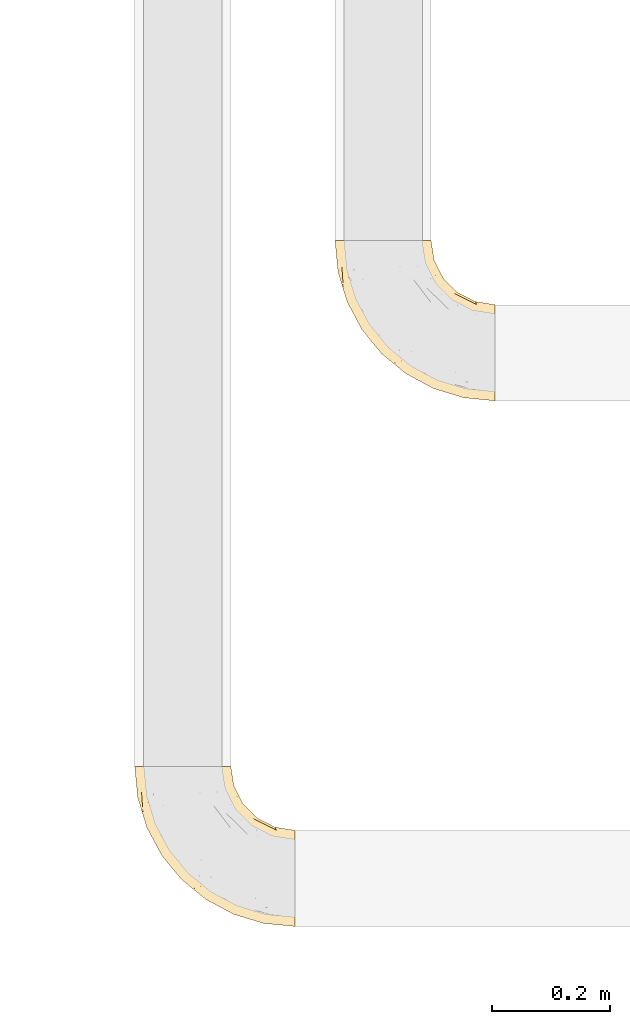
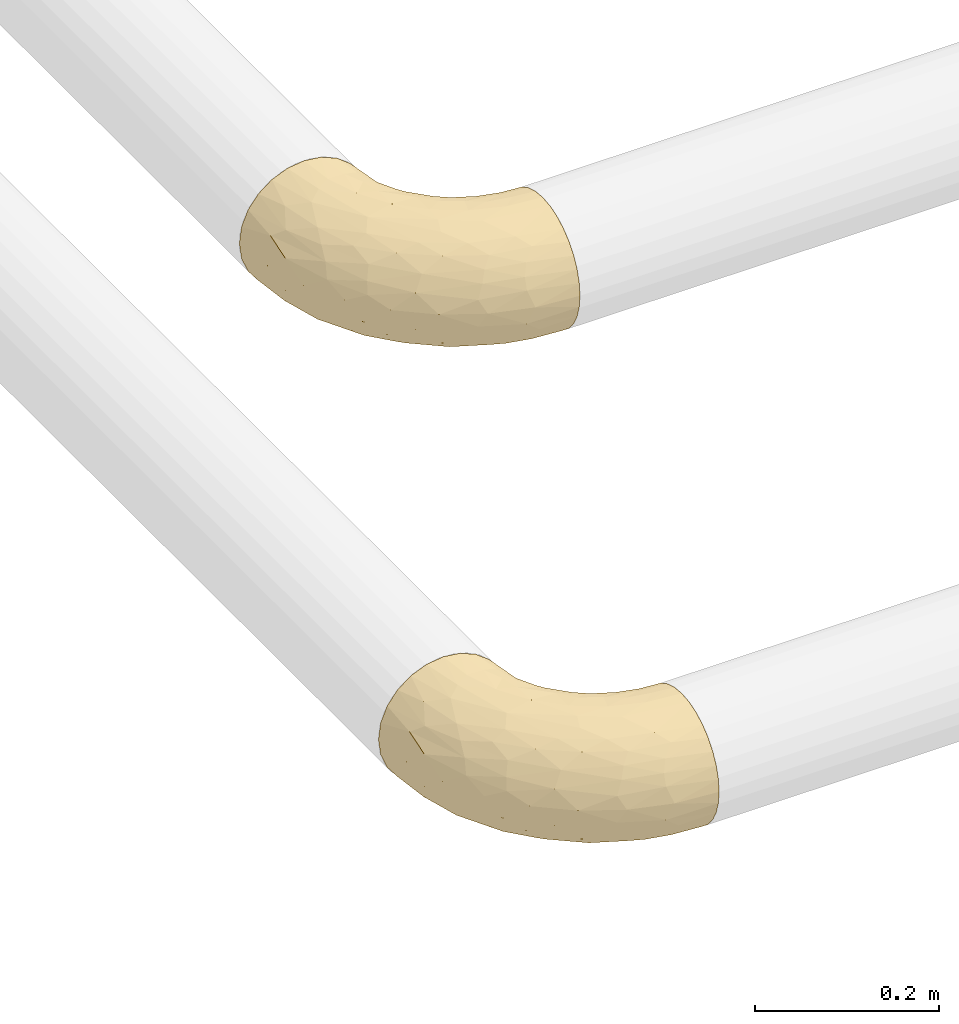
# One storey, part 97 of 827: 2 coverings.
"""IFC2X3 building model written with IfcOpenShell, lengths in millimetres."""

from ifc_helpers import new_model, entity, si_unit, converted_unit, derived_unit, direction, frame, origin, place, context, subcontext, project, spatial, faceted_brep, element, save


model = new_model("IFC2X3")

# Units and contexts
model_context = context("Model", 3, precision=0.01, world=origin(), true_north=direction((6.12303176911189e-17, 1.0)))
body_context = subcontext(model_context, "Body", "Model", "MODEL_VIEW")
ifc_project = project(units=[si_unit("LENGTHUNIT", "METRE", prefix="MILLI"), si_unit("AREAUNIT", "SQUARE_METRE"), si_unit("VOLUMEUNIT", "CUBIC_METRE"), converted_unit("PLANEANGLEUNIT", "DEGREE", entity("IfcRatioMeasure", 0.0174532925199433), si_unit("PLANEANGLEUNIT", "RADIAN"), dimensions=[0, 0, 0, 0, 0, 0, 0]), si_unit("MASSUNIT", "GRAM", prefix="KILO"), derived_unit("MASSDENSITYUNIT", [(si_unit("MASSUNIT", "GRAM", prefix="KILO"), 1), (si_unit("LENGTHUNIT", "METRE"), -3)]), derived_unit("MOMENTOFINERTIAUNIT", [(si_unit("LENGTHUNIT", "METRE"), 4)]), si_unit("TIMEUNIT", "SECOND"), si_unit("FREQUENCYUNIT", "HERTZ"), si_unit("THERMODYNAMICTEMPERATUREUNIT", "DEGREE_CELSIUS"), derived_unit("THERMALTRANSMITTANCEUNIT", [(si_unit("MASSUNIT", "GRAM", prefix="KILO"), 1), (si_unit("THERMODYNAMICTEMPERATUREUNIT", "KELVIN"), -1), (si_unit("TIMEUNIT", "SECOND"), -3)]), derived_unit("VOLUMETRICFLOWRATEUNIT", [(si_unit("LENGTHUNIT", "METRE"), 3), (si_unit("TIMEUNIT", "SECOND"), -1)]), derived_unit("MASSFLOWRATEUNIT", [(si_unit("MASSUNIT", "GRAM", prefix="KILO"), 1), (si_unit("TIMEUNIT", "SECOND"), -1)]), derived_unit("ROTATIONALFREQUENCYUNIT", [(si_unit("TIMEUNIT", "SECOND"), -1)]), si_unit("ELECTRICCURRENTUNIT", "AMPERE"), si_unit("ELECTRICVOLTAGEUNIT", "VOLT"), si_unit("POWERUNIT", "WATT"), si_unit("FORCEUNIT", "NEWTON", prefix="KILO"), si_unit("ILLUMINANCEUNIT", "LUX"), si_unit("LUMINOUSFLUXUNIT", "LUMEN"), si_unit("LUMINOUSINTENSITYUNIT", "CANDELA"), derived_unit("USERDEFINED", [(si_unit("MASSUNIT", "GRAM", prefix="KILO"), -1), (si_unit("LENGTHUNIT", "METRE"), -2), (si_unit("TIMEUNIT", "SECOND"), 3), (si_unit("LUMINOUSFLUXUNIT", "LUMEN"), 1)]), derived_unit("LINEARVELOCITYUNIT", [(si_unit("LENGTHUNIT", "METRE"), 1), (si_unit("TIMEUNIT", "SECOND"), -1)]), si_unit("PRESSUREUNIT", "PASCAL"), derived_unit("USERDEFINED", [(si_unit("LENGTHUNIT", "METRE"), -2), (si_unit("MASSUNIT", "GRAM", prefix="KILO"), 1), (si_unit("TIMEUNIT", "SECOND"), -2)]), derived_unit("LINEARFORCEUNIT", [(si_unit("MASSUNIT", "GRAM", prefix="KILO"), 1), (si_unit("LENGTHUNIT", "METRE"), 1), (si_unit("TIMEUNIT", "SECOND"), -2), (si_unit("LENGTHUNIT", "METRE"), -1)]), derived_unit("PLANARFORCEUNIT", [(si_unit("MASSUNIT", "GRAM", prefix="KILO"), 1), (si_unit("LENGTHUNIT", "METRE"), 1), (si_unit("TIMEUNIT", "SECOND"), -2), (si_unit("LENGTHUNIT", "METRE"), -2)])], contexts=[model_context])

# Site, building, storey
site_placement = place(None, origin())
site = spatial("IfcSite", under=ifc_project, at=site_placement, CompositionType="ELEMENT")
building_placement = place(site_placement, origin())
building = spatial("IfcBuilding", under=site, at=building_placement, CompositionType="ELEMENT")
storey_placement = place(building_placement, frame((0.0, 0.0, 28200.0)))
storey = spatial("IfcBuildingStorey", under=building, at=storey_placement, Name="08", CompositionType="ELEMENT", Elevation=28200.0)

# Coverings
covering_1_placement = place(storey_placement, frame((22091.66, 7183.11, 2716.91)))
element("IfcCovering", 1, at=covering_1_placement, inside=storey, Name=":ADSK_", ObjectType=":ADSK_", PredefinedType="INSULATION", context=body_context, shape_type="Brep", body=[
    faceted_brep([(273.1, 51.91, 158.39), (273.1, 37.82, 150.86), (273.1, 25.47, 140.72), (273.1, 15.33, 128.37), (273.1, 7.8, 114.28), (273.1, 3.16, 98.99), (273.1, 1.6, 83.1), (273.1, 3.16, 67.2), (273.1, 7.8, 51.91), (273.1, 15.33, 37.82), (273.1, 25.47, 25.47), (273.1, 37.82, 15.33), (273.1, 51.91, 7.8), (273.1, 67.2, 3.16), (273.1, 83.1, 1.6), (273.1, 99.0, 3.16), (273.1, 114.28, 7.8), (273.1, 128.37, 15.33), (273.1, 140.72, 25.47), (273.1, 150.86, 37.82), (273.1, 158.39, 51.91), (273.1, 163.03, 67.2), (273.1, 164.6, 83.1), (273.1, 163.03, 99.0), (273.1, 158.39, 114.28), (273.1, 150.86, 128.37), (273.1, 140.72, 140.72), (273.1, 128.37, 150.86), (273.1, 114.28, 158.39), (273.1, 98.99, 163.03), (273.1, 83.1, 164.6), (273.1, 67.2, 163.03), (161.82, 273.1, 62.0), (153.68, 273.1, 42.35), (140.72, 273.1, 25.47), (123.85, 273.1, 12.51), (104.19, 273.1, 4.37), (83.1, 273.1, 1.6), (62.0, 273.1, 4.37), (42.35, 273.1, 12.51), (25.47, 273.1, 25.47), (12.51, 273.1, 42.35), (4.37, 273.1, 62.0), (1.6, 273.1, 83.1), (4.37, 273.1, 104.19), (12.51, 273.1, 123.85), (25.47, 273.1, 140.72), (42.35, 273.1, 153.68), (62.0, 273.1, 161.82), (83.1, 273.1, 164.6), (104.19, 273.1, 161.82), (123.85, 273.1, 153.68), (140.72, 273.1, 140.72), (153.68, 273.1, 123.85), (161.82, 273.1, 104.19), (164.6, 273.1, 83.1), (15.45, 197.18, 104.67), (6.81, 220.13, 83.1), (22.26, 169.2, 83.1), (42.42, 165.22, 132.71), (71.44, 112.74, 128.57), (65.97, 136.63, 140.31), (113.44, 69.59, 127.0), (65.75, 106.1, 111.93), (103.59, 65.75, 107.33), (63.94, 101.73, 96.47), (218.6, 47.92, 153.13), (39.77, 151.7, 119.3), (36.91, 143.42, 101.32), (138.84, 67.74, 142.92), (183.71, 44.25, 142.61), (168.19, 64.23, 151.87), (71.48, 221.53, 162.56), (101.91, 190.66, 164.6), (87.86, 230.82, 164.6), (47.35, 122.26, 83.1), (167.63, 31.44, 117.97), (212.84, 17.25, 119.64), (173.72, 37.36, 131.15), (81.12, 81.12, 83.1), (122.26, 47.35, 83.1), (56.45, 210.98, 156.52), (46.95, 181.7, 144.21), (35.05, 232.28, 146.25), (24.32, 211.28, 130.43), (230.82, 87.86, 164.6), (195.92, 79.61, 162.51), (92.81, 152.2, 159.97), (82.34, 136.41, 151.26), (122.78, 92.77, 151.21), (13.53, 226.05, 117.68), (149.02, 89.58, 158.25), (154.38, 104.94, 163.04), (212.27, 11.64, 105.24), (160.47, 28.2, 100.78), (230.92, 33.2, 144.52), (98.82, 98.82, 141.87), (218.75, 24.35, 132.77), (169.2, 22.26, 83.1), (220.13, 6.81, 83.1), (190.66, 101.91, 164.6), (154.63, 124.55, 164.6), (124.55, 154.63, 164.6), (131.16, 242.08, 151.23), (150.42, 231.65, 137.69), (110.62, 233.63, 161.34), (211.28, 155.43, 141.27), (240.6, 146.77, 138.72), (223.71, 162.22, 127.05), (203.39, 184.19, 109.71), (239.57, 169.91, 83.1), (209.32, 185.32, 83.1), (171.53, 213.9, 120.43), (166.55, 197.8, 138.75), (191.93, 180.95, 129.2), (173.04, 136.57, 161.91), (198.01, 123.35, 161.43), (187.52, 145.64, 155.97), (125.16, 185.45, 162.57), (157.77, 157.77, 160.03), (158.24, 182.66, 151.82), (160.57, 245.12, 117.14), (242.02, 164.57, 109.48), (248.61, 133.28, 148.92), (220.59, 136.47, 151.93), (137.18, 206.49, 154.85), (165.92, 248.1, 98.92), (175.12, 222.02, 100.98), (185.32, 209.32, 83.1), (169.91, 239.57, 83.1), (184.45, 167.88, 145.5), (238.32, 118.7, 158.16), (217.41, 108.44, 162.97), (245.77, 102.71, 162.71), (190.73, 200.15, 98.76), (121.56, 211.84, 160.15), (249.77, 155.81, 124.12), (171.52, 162.83, 154.06), (137.18, 206.49, 11.34), (150.42, 231.65, 28.5), (166.55, 197.8, 27.44), (158.24, 182.66, 14.37), (165.92, 248.1, 67.27), (175.12, 222.02, 65.22), (223.71, 162.22, 39.14), (211.28, 155.43, 24.93), (191.92, 180.95, 36.99), (245.77, 102.71, 3.48), (203.4, 184.19, 56.48), (131.16, 242.08, 14.96), (110.62, 233.63, 4.85), (249.77, 155.81, 42.07), (240.6, 146.78, 27.47), (171.53, 213.9, 45.76), (190.73, 200.15, 67.43), (217.41, 108.44, 3.22), (238.31, 118.7, 8.03), (87.86, 230.82, 1.6), (160.57, 245.12, 49.05), (248.61, 133.28, 17.27), (242.02, 164.57, 56.71), (111.86, 206.34, 3.08), (125.16, 185.45, 3.62), (190.66, 101.91, 1.6), (154.63, 124.55, 1.6), (198.01, 123.35, 4.76), (124.55, 154.63, 1.6), (101.91, 190.66, 1.6), (184.45, 167.88, 20.69), (157.77, 157.77, 6.16), (220.59, 136.47, 14.26), (187.52, 145.64, 10.22), (173.04, 136.57, 4.28), (230.82, 87.86, 1.6), (171.95, 162.96, 12.35), (24.32, 211.28, 35.76), (183.71, 44.25, 23.58), (173.75, 37.35, 35.03), (133.19, 59.81, 34.03), (229.24, 14.04, 46.35), (79.61, 195.92, 3.68), (104.94, 154.38, 3.15), (89.58, 149.02, 7.94), (98.82, 98.82, 24.32), (84.08, 94.45, 41.48), (152.2, 92.81, 6.22), (198.75, 82.48, 2.91), (62.55, 108.3, 57.48), (58.85, 198.33, 10.43), (40.65, 169.99, 33.0), (46.95, 181.7, 21.98), (63.87, 135.99, 28.1), (22.06, 192.96, 47.91), (230.92, 33.21, 21.67), (103.59, 65.75, 58.86), (207.65, 49.37, 13.93), (39.77, 151.7, 46.9), (34.68, 148.6, 62.93), (35.05, 232.28, 19.94), (15.45, 197.18, 61.52), (150.41, 72.78, 15.08), (210.73, 63.87, 6.68), (160.46, 28.2, 65.41), (79.42, 136.17, 16.65), (115.1, 107.34, 11.53), (212.26, 11.64, 60.95), (218.75, 24.35, 33.42), (167.63, 31.44, 48.22)], [[[0, 1, 2, 3, 4, 5, 6, 7, 8, 9, 10, 11, 12, 13, 14, 15, 16, 17, 18, 19, 20, 21, 22, 23, 24, 25, 26, 27, 28, 29, 30, 31]], [[32, 33, 34, 35, 36, 37, 38, 39, 40, 41, 42, 43, 44, 45, 46, 47, 48, 49, 50, 51, 52, 53, 54, 55]], [[56, 57, 58]], [[57, 44, 43]], [[59, 60, 61]], [[62, 63, 64]], [[63, 65, 64]], [[1, 0, 66]], [[67, 68, 63]], [[69, 70, 71]], [[72, 73, 74]], [[75, 68, 58]], [[76, 77, 78]], [[64, 79, 80]], [[81, 48, 47]], [[82, 83, 84]], [[31, 85, 86]], [[71, 70, 66]], [[47, 83, 81]], [[87, 88, 89]], [[69, 62, 78]], [[49, 48, 72]], [[90, 44, 56]], [[48, 81, 72]], [[87, 91, 92]], [[93, 76, 94]], [[70, 95, 66]], [[88, 96, 89]], [[45, 84, 46]], [[2, 95, 97]], [[4, 93, 5]], [[98, 99, 93]], [[59, 84, 67]], [[3, 97, 77]], [[71, 86, 91]], [[4, 3, 77]], [[90, 84, 45]], [[99, 6, 5]], [[83, 47, 46]], [[95, 2, 1]], [[94, 80, 98]], [[100, 101, 92]], [[66, 31, 86]], [[60, 63, 62]], [[85, 31, 30]], [[102, 87, 92]], [[93, 77, 76]], [[91, 86, 92]], [[44, 57, 56]], [[86, 85, 100]], [[78, 97, 70]], [[87, 102, 73]], [[2, 97, 3]], [[67, 84, 90]], [[31, 66, 0]], [[93, 94, 98]], [[88, 81, 82]], [[99, 5, 93]], [[87, 73, 72]], [[66, 95, 1]], [[97, 95, 70]], [[86, 71, 66]], [[69, 89, 96]], [[89, 71, 91]], [[69, 96, 62]], [[60, 62, 96]], [[76, 62, 64]], [[71, 89, 69]], [[87, 89, 91]], [[81, 88, 87]], [[61, 88, 82]], [[61, 60, 96]], [[60, 67, 63]], [[68, 67, 56]], [[79, 65, 75]], [[58, 68, 56]], [[65, 68, 75]], [[64, 65, 79]], [[68, 65, 63]], [[76, 64, 94]], [[80, 94, 64]], [[100, 92, 86]], [[92, 101, 102]], [[88, 61, 96]], [[59, 61, 82]], [[84, 59, 82]], [[60, 59, 67]], [[87, 72, 81]], [[49, 72, 74]], [[84, 83, 46]], [[81, 83, 82]], [[69, 78, 70]], [[62, 76, 78]], [[4, 77, 93]], [[78, 77, 97]], [[44, 90, 45]], [[67, 90, 56]], [[103, 104, 52]], [[50, 49, 74]], [[50, 74, 105]], [[106, 107, 108]], [[109, 110, 111]], [[112, 113, 114]], [[104, 113, 112]], [[73, 105, 74]], [[115, 116, 117]], [[118, 119, 120]], [[104, 53, 52]], [[51, 103, 52]], [[53, 121, 54]], [[24, 23, 122]], [[123, 107, 124]], [[122, 109, 108]], [[125, 120, 113]], [[55, 54, 126]], [[102, 118, 73]], [[127, 126, 121]], [[128, 129, 127]], [[105, 51, 50]], [[102, 101, 119]], [[120, 130, 113]], [[26, 123, 27]], [[27, 131, 28]], [[132, 85, 133]], [[85, 29, 133]], [[134, 111, 128]], [[28, 133, 29]], [[30, 29, 85]], [[116, 131, 124]], [[135, 73, 118]], [[27, 123, 131]], [[110, 23, 22]], [[136, 122, 108]], [[24, 136, 25]], [[114, 108, 109]], [[119, 115, 117]], [[136, 107, 25]], [[128, 127, 134]], [[122, 110, 109]], [[104, 112, 121]], [[107, 106, 124]], [[107, 26, 25]], [[23, 110, 122]], [[101, 100, 116]], [[131, 132, 133]], [[105, 135, 103]], [[116, 124, 117]], [[122, 136, 24]], [[107, 136, 108]], [[28, 131, 133]], [[131, 116, 132]], [[126, 127, 129]], [[134, 112, 109]], [[107, 123, 26]], [[131, 123, 124]], [[104, 121, 53]], [[127, 121, 112]], [[105, 103, 51]], [[104, 103, 125]], [[116, 100, 132]], [[85, 132, 100]], [[106, 117, 124]], [[137, 130, 120]], [[114, 106, 108]], [[106, 130, 117]], [[119, 118, 102]], [[135, 118, 125]], [[125, 113, 104]], [[114, 113, 130]], [[114, 130, 106]], [[112, 114, 109]], [[118, 120, 125]], [[117, 137, 119]], [[55, 126, 129]], [[121, 126, 54]], [[112, 134, 127]], [[111, 134, 109]], [[119, 101, 115]], [[101, 116, 115]], [[103, 135, 125]], [[73, 135, 105]], [[130, 137, 117]], [[120, 119, 137]], [[138, 139, 140]], [[140, 141, 138]], [[55, 129, 142]], [[143, 142, 129]], [[144, 145, 146]], [[147, 16, 15]], [[110, 148, 111]], [[128, 143, 129]], [[149, 150, 35]], [[151, 152, 144]], [[153, 143, 154]], [[147, 155, 156]], [[35, 150, 36]], [[37, 36, 157]], [[35, 34, 149]], [[139, 33, 158]], [[159, 152, 18]], [[150, 157, 36]], [[140, 139, 153]], [[139, 34, 33]], [[110, 21, 160]], [[150, 161, 157]], [[20, 19, 151]], [[161, 138, 162]], [[110, 22, 21]], [[163, 164, 165]], [[166, 167, 162]], [[151, 160, 20]], [[140, 146, 168]], [[111, 148, 154]], [[164, 166, 169]], [[18, 152, 19]], [[170, 156, 165]], [[17, 159, 18]], [[158, 33, 32]], [[171, 165, 172]], [[155, 165, 156]], [[148, 110, 160]], [[170, 159, 156]], [[160, 144, 148]], [[15, 14, 173]], [[170, 171, 145]], [[149, 139, 138]], [[15, 173, 147]], [[144, 152, 145]], [[156, 17, 16]], [[165, 171, 170]], [[20, 160, 21]], [[171, 172, 169]], [[169, 166, 162]], [[152, 151, 19]], [[160, 151, 144]], [[155, 173, 163]], [[156, 16, 147]], [[154, 143, 128]], [[143, 153, 158]], [[156, 159, 17]], [[152, 159, 170]], [[158, 32, 142]], [[139, 158, 153]], [[139, 149, 34]], [[150, 149, 138]], [[173, 155, 147]], [[163, 165, 155]], [[174, 169, 141]], [[145, 171, 168]], [[170, 145, 152]], [[146, 145, 168]], [[161, 162, 167]], [[162, 138, 141]], [[146, 153, 148]], [[140, 168, 141]], [[153, 146, 140]], [[144, 146, 148]], [[174, 141, 168]], [[162, 141, 169]], [[158, 142, 143]], [[55, 142, 32]], [[111, 154, 128]], [[153, 154, 148]], [[165, 164, 172]], [[164, 169, 172]], [[157, 161, 167]], [[138, 161, 150]], [[168, 171, 174]], [[169, 174, 171]], [[41, 40, 175]], [[176, 177, 178]], [[9, 8, 179]], [[180, 181, 182]], [[157, 180, 37]], [[183, 178, 184]], [[164, 185, 181]], [[13, 186, 173]], [[187, 79, 75]], [[167, 166, 181]], [[186, 163, 173]], [[182, 188, 180]], [[57, 43, 42]], [[189, 190, 191]], [[164, 186, 185]], [[192, 41, 175]], [[193, 11, 10]], [[178, 194, 184]], [[12, 11, 195]], [[196, 187, 197]], [[40, 198, 175]], [[198, 40, 39]], [[58, 199, 197]], [[200, 185, 201]], [[163, 186, 164]], [[201, 185, 186]], [[202, 80, 194]], [[190, 203, 191]], [[201, 186, 13]], [[204, 185, 200]], [[201, 13, 12]], [[41, 199, 42]], [[195, 200, 201]], [[98, 205, 99]], [[57, 42, 199]], [[13, 173, 14]], [[58, 57, 199]], [[193, 206, 176]], [[80, 79, 194]], [[207, 205, 202]], [[196, 184, 187]], [[202, 205, 98]], [[205, 179, 8]], [[9, 206, 10]], [[207, 206, 179]], [[182, 203, 188]], [[6, 99, 7]], [[188, 38, 180]], [[203, 182, 204]], [[7, 205, 8]], [[37, 180, 38]], [[167, 180, 157]], [[7, 99, 205]], [[182, 181, 185]], [[11, 193, 195]], [[196, 191, 184]], [[175, 189, 192]], [[198, 188, 190]], [[38, 188, 39]], [[206, 193, 10]], [[195, 193, 176]], [[195, 176, 200]], [[12, 195, 201]], [[178, 200, 176]], [[185, 204, 182]], [[200, 183, 204]], [[203, 204, 183]], [[191, 203, 183]], [[188, 203, 190]], [[184, 191, 183]], [[190, 189, 175]], [[200, 178, 183]], [[184, 194, 187]], [[177, 176, 206]], [[194, 178, 207]], [[79, 187, 194]], [[197, 199, 192]], [[187, 75, 197]], [[58, 197, 75]], [[191, 196, 189]], [[192, 189, 196]], [[80, 202, 98]], [[194, 207, 202]], [[167, 181, 180]], [[181, 166, 164]], [[188, 198, 39]], [[175, 198, 190]], [[207, 179, 205]], [[9, 179, 206]], [[197, 192, 196]], [[41, 192, 199]], [[206, 207, 177]], [[207, 178, 177]]]),
])
covering_2_placement = place(storey_placement, frame((21752.01, 6291.9, 2716.9)))
element("IfcCovering", 2, at=covering_2_placement, inside=storey, Name=":ADSK_", ObjectType=":ADSK_", PredefinedType="INSULATION", context=body_context, shape_type="Brep", body=[
    faceted_brep([(273.1, 51.91, 158.39), (273.1, 37.82, 150.86), (273.1, 25.47, 140.72), (273.1, 15.33, 128.37), (273.1, 7.8, 114.28), (273.1, 3.16, 98.99), (273.1, 1.6, 83.1), (273.1, 3.16, 67.2), (273.1, 7.8, 51.91), (273.1, 15.33, 37.82), (273.1, 25.47, 25.47), (273.1, 37.82, 15.33), (273.1, 51.91, 7.8), (273.1, 67.2, 3.16), (273.1, 83.1, 1.6), (273.1, 99.0, 3.16), (273.1, 114.28, 7.8), (273.1, 128.37, 15.33), (273.1, 140.72, 25.47), (273.1, 150.86, 37.82), (273.1, 158.39, 51.91), (273.1, 163.03, 67.2), (273.1, 164.6, 83.1), (273.1, 163.03, 99.0), (273.1, 158.39, 114.28), (273.1, 150.86, 128.37), (273.1, 140.72, 140.72), (273.1, 128.37, 150.86), (273.1, 114.28, 158.39), (273.1, 98.99, 163.03), (273.1, 83.1, 164.6), (273.1, 67.2, 163.03), (161.82, 273.1, 62.0), (153.68, 273.1, 42.35), (140.72, 273.1, 25.47), (123.85, 273.1, 12.51), (104.19, 273.1, 4.37), (83.1, 273.1, 1.6), (62.0, 273.1, 4.37), (42.35, 273.1, 12.51), (25.47, 273.1, 25.47), (12.51, 273.1, 42.35), (4.37, 273.1, 62.0), (1.6, 273.1, 83.1), (4.37, 273.1, 104.19), (12.51, 273.1, 123.85), (25.47, 273.1, 140.72), (42.35, 273.1, 153.68), (62.0, 273.1, 161.82), (83.1, 273.1, 164.6), (104.19, 273.1, 161.82), (123.85, 273.1, 153.68), (140.72, 273.1, 140.72), (153.68, 273.1, 123.85), (161.82, 273.1, 104.19), (164.6, 273.1, 83.1), (15.45, 197.18, 104.67), (6.81, 220.13, 83.1), (22.26, 169.2, 83.1), (42.42, 165.22, 132.71), (71.44, 112.74, 128.57), (65.97, 136.63, 140.31), (113.44, 69.59, 127.0), (65.75, 106.1, 111.93), (103.59, 65.75, 107.33), (63.94, 101.73, 96.47), (218.6, 47.92, 153.13), (39.77, 151.7, 119.3), (36.91, 143.42, 101.32), (138.84, 67.74, 142.92), (183.71, 44.25, 142.61), (168.19, 64.23, 151.87), (71.48, 221.53, 162.56), (101.91, 190.66, 164.6), (87.86, 230.82, 164.6), (47.35, 122.26, 83.1), (167.63, 31.44, 117.97), (212.84, 17.25, 119.64), (173.72, 37.36, 131.15), (81.12, 81.12, 83.1), (122.26, 47.35, 83.1), (56.45, 210.98, 156.52), (46.95, 181.7, 144.21), (35.05, 232.28, 146.25), (24.32, 211.28, 130.43), (230.82, 87.86, 164.6), (195.92, 79.61, 162.51), (92.81, 152.2, 159.97), (82.34, 136.41, 151.26), (122.78, 92.77, 151.21), (13.53, 226.05, 117.68), (149.02, 89.58, 158.25), (154.38, 104.94, 163.04), (212.27, 11.64, 105.24), (160.47, 28.2, 100.78), (230.92, 33.2, 144.52), (98.82, 98.82, 141.87), (218.75, 24.35, 132.77), (169.2, 22.26, 83.1), (220.13, 6.81, 83.1), (190.66, 101.91, 164.6), (154.63, 124.55, 164.6), (124.55, 154.63, 164.6), (131.16, 242.08, 151.23), (150.42, 231.65, 137.69), (110.62, 233.63, 161.34), (211.28, 155.43, 141.27), (240.6, 146.77, 138.72), (223.71, 162.22, 127.05), (203.39, 184.19, 109.71), (239.57, 169.91, 83.1), (209.32, 185.32, 83.1), (171.53, 213.9, 120.43), (166.55, 197.8, 138.75), (191.93, 180.95, 129.2), (173.04, 136.57, 161.91), (198.01, 123.35, 161.43), (187.52, 145.64, 155.97), (125.16, 185.45, 162.57), (157.77, 157.77, 160.03), (158.24, 182.66, 151.82), (160.57, 245.12, 117.14), (242.02, 164.57, 109.48), (248.61, 133.28, 148.92), (220.59, 136.47, 151.93), (137.18, 206.49, 154.85), (165.92, 248.1, 98.92), (175.12, 222.02, 100.98), (185.32, 209.32, 83.1), (169.91, 239.57, 83.1), (184.45, 167.88, 145.5), (238.32, 118.7, 158.16), (217.41, 108.44, 162.97), (245.77, 102.71, 162.71), (190.73, 200.15, 98.76), (121.56, 211.84, 160.15), (249.77, 155.81, 124.12), (171.52, 162.83, 154.06), (137.18, 206.49, 11.34), (150.42, 231.65, 28.5), (166.55, 197.8, 27.44), (158.24, 182.66, 14.37), (165.92, 248.1, 67.27), (175.12, 222.02, 65.22), (223.71, 162.22, 39.14), (211.28, 155.43, 24.93), (191.92, 180.95, 36.99), (245.77, 102.71, 3.48), (203.4, 184.19, 56.48), (131.16, 242.08, 14.96), (110.62, 233.63, 4.85), (249.77, 155.81, 42.07), (240.6, 146.78, 27.47), (171.53, 213.9, 45.76), (190.73, 200.15, 67.43), (217.41, 108.44, 3.22), (238.31, 118.7, 8.03), (87.86, 230.82, 1.6), (160.57, 245.12, 49.05), (248.61, 133.28, 17.27), (242.02, 164.57, 56.71), (111.86, 206.34, 3.08), (125.16, 185.45, 3.62), (190.66, 101.91, 1.6), (154.63, 124.55, 1.6), (198.01, 123.35, 4.76), (124.55, 154.63, 1.6), (101.91, 190.66, 1.6), (184.45, 167.88, 20.69), (157.77, 157.77, 6.16), (220.59, 136.47, 14.26), (187.52, 145.64, 10.22), (173.04, 136.57, 4.28), (230.82, 87.86, 1.6), (171.95, 162.96, 12.35), (24.32, 211.28, 35.76), (183.71, 44.25, 23.58), (173.75, 37.35, 35.03), (133.19, 59.81, 34.03), (229.24, 14.04, 46.35), (79.61, 195.92, 3.68), (104.94, 154.38, 3.15), (89.58, 149.02, 7.94), (98.82, 98.82, 24.32), (84.08, 94.45, 41.48), (152.2, 92.81, 6.22), (198.75, 82.48, 2.91), (62.55, 108.3, 57.48), (58.85, 198.33, 10.43), (40.65, 169.99, 33.0), (46.95, 181.7, 21.98), (63.87, 135.99, 28.1), (22.06, 192.96, 47.91), (230.92, 33.21, 21.67), (103.59, 65.75, 58.86), (207.65, 49.37, 13.93), (39.77, 151.7, 46.89), (34.68, 148.6, 62.93), (35.05, 232.28, 19.94), (15.45, 197.18, 61.52), (150.41, 72.78, 15.08), (210.73, 63.87, 6.68), (160.46, 28.2, 65.41), (79.42, 136.17, 16.65), (115.1, 107.34, 11.53), (212.26, 11.64, 60.95), (218.75, 24.35, 33.42), (167.63, 31.44, 48.22)], [[[0, 1, 2, 3, 4, 5, 6, 7, 8, 9, 10, 11, 12, 13, 14, 15, 16, 17, 18, 19, 20, 21, 22, 23, 24, 25, 26, 27, 28, 29, 30, 31]], [[32, 33, 34, 35, 36, 37, 38, 39, 40, 41, 42, 43, 44, 45, 46, 47, 48, 49, 50, 51, 52, 53, 54, 55]], [[56, 57, 58]], [[57, 44, 43]], [[59, 60, 61]], [[62, 63, 64]], [[63, 65, 64]], [[1, 0, 66]], [[67, 68, 63]], [[69, 70, 71]], [[72, 73, 74]], [[75, 68, 58]], [[76, 77, 78]], [[64, 79, 80]], [[81, 48, 47]], [[82, 83, 84]], [[31, 85, 86]], [[71, 70, 66]], [[47, 83, 81]], [[87, 88, 89]], [[69, 62, 78]], [[49, 48, 72]], [[90, 44, 56]], [[48, 81, 72]], [[87, 91, 92]], [[93, 76, 94]], [[70, 95, 66]], [[88, 96, 89]], [[45, 84, 46]], [[2, 95, 97]], [[4, 93, 5]], [[98, 99, 93]], [[59, 84, 67]], [[3, 97, 77]], [[71, 86, 91]], [[4, 3, 77]], [[90, 84, 45]], [[99, 6, 5]], [[83, 47, 46]], [[95, 2, 1]], [[94, 80, 98]], [[100, 101, 92]], [[66, 31, 86]], [[60, 63, 62]], [[85, 31, 30]], [[102, 87, 92]], [[93, 77, 76]], [[91, 86, 92]], [[44, 57, 56]], [[86, 85, 100]], [[78, 97, 70]], [[87, 102, 73]], [[2, 97, 3]], [[67, 84, 90]], [[31, 66, 0]], [[93, 94, 98]], [[88, 81, 82]], [[99, 5, 93]], [[87, 73, 72]], [[66, 95, 1]], [[97, 95, 70]], [[86, 71, 66]], [[69, 89, 96]], [[89, 71, 91]], [[69, 96, 62]], [[60, 62, 96]], [[76, 62, 64]], [[71, 89, 69]], [[87, 89, 91]], [[81, 88, 87]], [[61, 88, 82]], [[61, 60, 96]], [[60, 67, 63]], [[68, 67, 56]], [[79, 65, 75]], [[58, 68, 56]], [[65, 68, 75]], [[64, 65, 79]], [[68, 65, 63]], [[76, 64, 94]], [[80, 94, 64]], [[100, 92, 86]], [[92, 101, 102]], [[88, 61, 96]], [[59, 61, 82]], [[84, 59, 82]], [[60, 59, 67]], [[87, 72, 81]], [[49, 72, 74]], [[84, 83, 46]], [[81, 83, 82]], [[69, 78, 70]], [[62, 76, 78]], [[4, 77, 93]], [[78, 77, 97]], [[44, 90, 45]], [[67, 90, 56]], [[103, 104, 52]], [[50, 49, 74]], [[50, 74, 105]], [[106, 107, 108]], [[109, 110, 111]], [[112, 113, 114]], [[104, 113, 112]], [[73, 105, 74]], [[115, 116, 117]], [[118, 119, 120]], [[104, 53, 52]], [[51, 103, 52]], [[53, 121, 54]], [[24, 23, 122]], [[123, 107, 124]], [[122, 109, 108]], [[125, 120, 113]], [[55, 54, 126]], [[102, 118, 73]], [[127, 126, 121]], [[128, 129, 127]], [[105, 51, 50]], [[102, 101, 119]], [[120, 130, 113]], [[26, 123, 27]], [[27, 131, 28]], [[132, 85, 133]], [[85, 29, 133]], [[134, 111, 128]], [[28, 133, 29]], [[30, 29, 85]], [[116, 131, 124]], [[135, 73, 118]], [[27, 123, 131]], [[110, 23, 22]], [[136, 122, 108]], [[24, 136, 25]], [[114, 108, 109]], [[119, 115, 117]], [[136, 107, 25]], [[128, 127, 134]], [[122, 110, 109]], [[104, 112, 121]], [[107, 106, 124]], [[107, 26, 25]], [[23, 110, 122]], [[101, 100, 116]], [[131, 132, 133]], [[105, 135, 103]], [[116, 124, 117]], [[122, 136, 24]], [[107, 136, 108]], [[28, 131, 133]], [[131, 116, 132]], [[126, 127, 129]], [[134, 112, 109]], [[107, 123, 26]], [[131, 123, 124]], [[104, 121, 53]], [[127, 121, 112]], [[105, 103, 51]], [[104, 103, 125]], [[116, 100, 132]], [[85, 132, 100]], [[106, 117, 124]], [[137, 130, 120]], [[114, 106, 108]], [[106, 130, 117]], [[119, 118, 102]], [[135, 118, 125]], [[125, 113, 104]], [[114, 113, 130]], [[114, 130, 106]], [[112, 114, 109]], [[118, 120, 125]], [[117, 137, 119]], [[55, 126, 129]], [[121, 126, 54]], [[112, 134, 127]], [[111, 134, 109]], [[119, 101, 115]], [[101, 116, 115]], [[103, 135, 125]], [[73, 135, 105]], [[130, 137, 117]], [[120, 119, 137]], [[138, 139, 140]], [[140, 141, 138]], [[55, 129, 142]], [[143, 142, 129]], [[144, 145, 146]], [[147, 16, 15]], [[110, 148, 111]], [[128, 143, 129]], [[149, 150, 35]], [[151, 152, 144]], [[153, 143, 154]], [[147, 155, 156]], [[35, 150, 36]], [[37, 36, 157]], [[35, 34, 149]], [[139, 33, 158]], [[159, 152, 18]], [[150, 157, 36]], [[140, 139, 153]], [[139, 34, 33]], [[110, 21, 160]], [[150, 161, 157]], [[20, 19, 151]], [[161, 138, 162]], [[110, 22, 21]], [[163, 164, 165]], [[166, 167, 162]], [[151, 160, 20]], [[140, 146, 168]], [[111, 148, 154]], [[164, 166, 169]], [[18, 152, 19]], [[170, 156, 165]], [[17, 159, 18]], [[158, 33, 32]], [[171, 165, 172]], [[155, 165, 156]], [[148, 110, 160]], [[170, 159, 156]], [[160, 144, 148]], [[15, 14, 173]], [[170, 171, 145]], [[149, 139, 138]], [[15, 173, 147]], [[144, 152, 145]], [[156, 17, 16]], [[165, 171, 170]], [[20, 160, 21]], [[171, 172, 169]], [[169, 166, 162]], [[152, 151, 19]], [[160, 151, 144]], [[155, 173, 163]], [[156, 16, 147]], [[154, 143, 128]], [[143, 153, 158]], [[156, 159, 17]], [[152, 159, 170]], [[158, 32, 142]], [[139, 158, 153]], [[139, 149, 34]], [[150, 149, 138]], [[173, 155, 147]], [[163, 165, 155]], [[174, 169, 141]], [[145, 171, 168]], [[170, 145, 152]], [[146, 145, 168]], [[161, 162, 167]], [[162, 138, 141]], [[146, 153, 148]], [[140, 168, 141]], [[153, 146, 140]], [[144, 146, 148]], [[174, 141, 168]], [[162, 141, 169]], [[158, 142, 143]], [[55, 142, 32]], [[111, 154, 128]], [[153, 154, 148]], [[165, 164, 172]], [[164, 169, 172]], [[157, 161, 167]], [[138, 161, 150]], [[168, 171, 174]], [[169, 174, 171]], [[41, 40, 175]], [[176, 177, 178]], [[9, 8, 179]], [[180, 181, 182]], [[157, 180, 37]], [[183, 178, 184]], [[164, 185, 181]], [[13, 186, 173]], [[187, 79, 75]], [[167, 166, 181]], [[186, 163, 173]], [[182, 188, 180]], [[57, 43, 42]], [[189, 190, 191]], [[164, 186, 185]], [[192, 41, 175]], [[193, 11, 10]], [[178, 194, 184]], [[12, 11, 195]], [[196, 187, 197]], [[40, 198, 175]], [[198, 40, 39]], [[58, 199, 197]], [[200, 185, 201]], [[163, 186, 164]], [[201, 185, 186]], [[202, 80, 194]], [[190, 203, 191]], [[201, 186, 13]], [[204, 185, 200]], [[201, 13, 12]], [[41, 199, 42]], [[195, 200, 201]], [[98, 205, 99]], [[57, 42, 199]], [[13, 173, 14]], [[58, 57, 199]], [[193, 206, 176]], [[80, 79, 194]], [[207, 205, 202]], [[196, 184, 187]], [[202, 205, 98]], [[205, 179, 8]], [[9, 206, 10]], [[207, 206, 179]], [[182, 203, 188]], [[6, 99, 7]], [[188, 38, 180]], [[203, 182, 204]], [[7, 205, 8]], [[37, 180, 38]], [[167, 180, 157]], [[7, 99, 205]], [[182, 181, 185]], [[11, 193, 195]], [[196, 191, 184]], [[175, 189, 192]], [[198, 188, 190]], [[38, 188, 39]], [[206, 193, 10]], [[195, 193, 176]], [[195, 176, 200]], [[12, 195, 201]], [[178, 200, 176]], [[185, 204, 182]], [[200, 183, 204]], [[203, 204, 183]], [[191, 203, 183]], [[188, 203, 190]], [[184, 191, 183]], [[190, 189, 175]], [[200, 178, 183]], [[184, 194, 187]], [[177, 176, 206]], [[194, 178, 207]], [[79, 187, 194]], [[197, 199, 192]], [[187, 75, 197]], [[58, 197, 75]], [[191, 196, 189]], [[192, 189, 196]], [[80, 202, 98]], [[194, 207, 202]], [[167, 181, 180]], [[181, 166, 164]], [[188, 198, 39]], [[175, 198, 190]], [[207, 179, 205]], [[9, 179, 206]], [[197, 192, 196]], [[41, 192, 199]], [[206, 207, 177]], [[207, 178, 177]]]),
])

save(model, "model.ifc")
